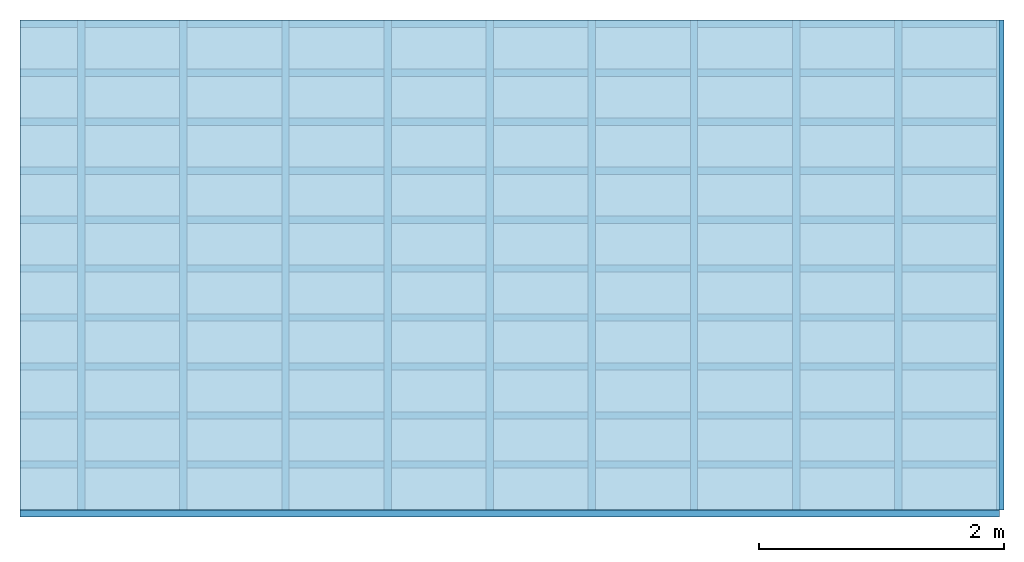
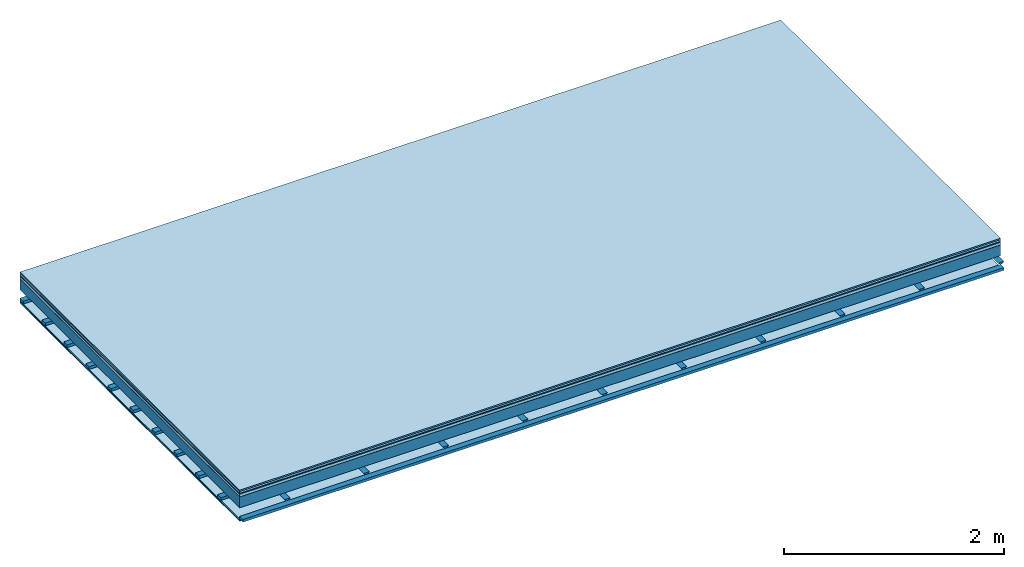
# One storey: 8 plates, 3 members, 1 element without a shape of its own.
"""IFC4 building model written with IfcOpenShell, lengths in metres."""

from ifc_helpers import new_model, si_unit, derived_unit, direction, frame, frame_2d, origin, origin_with_axes, place, context, project, spatial, polyline, rectangle, outline, extrude, material, layer, layer_set, type_object, element, aggregate, save


model = new_model("IFC4")

# Units and contexts
plan_context = context("Plan", 3, precision=1e-05, world=origin(), true_north=direction((0.0, 1.0)))
model_context = context("Model", 3, precision=1e-05, world=origin(), true_north=direction((0.0, 1.0)))
ifc_project = project(units=[si_unit("LENGTHUNIT", "METRE"), derived_unit("SOUNDPRESSUREUNIT", [(si_unit("PRESSUREUNIT", "PASCAL", prefix="MICRO"), 0)]), si_unit("ENERGYUNIT", "JOULE", prefix="MEGA"), si_unit("MASSUNIT", "GRAM", prefix="KILO"), derived_unit("THERMALTRANSMITTANCEUNIT", [(si_unit("POWERUNIT", "WATT"), 1), (si_unit("AREAUNIT", "SQUARE_METRE"), -1), (si_unit("THERMODYNAMICTEMPERATUREUNIT", "KELVIN"), -1)]), derived_unit("AREADENSITYUNIT", [(si_unit("MASSUNIT", "GRAM", prefix="KILO"), 1), (si_unit("AREAUNIT", "SQUARE_METRE"), -1)]), derived_unit("USERDEFINED", [(si_unit("ENERGYUNIT", "JOULE", prefix="MEGA"), 1), (si_unit("AREAUNIT", "SQUARE_METRE"), -1)])], contexts=[plan_context, model_context])

# Site, building, storey
site = spatial("IfcSite", under=ifc_project)
building_placement = place(None, origin())
building = spatial("IfcBuilding", under=site, at=building_placement)
storey_placement = place(building_placement, origin())
storey = spatial("IfcBuildingStorey", under=building, at=storey_placement)

# Slab, members, plates
ifc_material_1 = material(Category="11.013")
ifc_layer_1 = layer(ifc_material_1, 0.015, Name="Flooring")
ifc_material_2 = material(Category="03.007")
ifc_layer_2 = layer(ifc_material_2, 0.02, Name="On-material")
ifc_material_3 = material(Name="Wood fiber generic product", Category="10.009")
ifc_layer_3 = layer(ifc_material_3, 0.01, Name="Impact sound insulation")
ifc_material_4 = material(Name="with broken")
ifc_layer_4 = layer(ifc_material_4, 0.03, Name="on Supporting structure")
ifc_material_5 = material(Name="protection", Category="09.007")
ifc_layer_5 = layer(ifc_material_5, 0.0005, Name="Sub-floor")
ifc_material_6 = material(Name="no composite action")
ifc_layer_6 = layer(ifc_material_6, 0.0, Name="Bond")
ifc_layer_7 = layer(None, 0.12, Name="Supporting structure")
ifc_layer_8 = layer(ifc_material_6, 0.0, Name="Bond")
ifc_layer_9 = layer(None, 0.095, Name="Coupling")
ifc_layer_10 = layer(None, 0.03, Name="Battens / profiles")
ifc_material_7 = material(Name="Plasterboard type A", Category="03.008")
ifc_layer_11 = layer(ifc_material_7, 0.0125, Name="Ceiling covering 1st layer")
ifc_layer_12 = layer(ifc_material_7, 0.0125, Name="Ceiling covering layer 2")
ifc_material_8 = material(Category="04.001")
ifc_layer_13 = layer(ifc_material_8, 0.003, Name="Surface / treatment")
ifc_layer_set = layer_set([ifc_layer_1, ifc_layer_2, ifc_layer_3, ifc_layer_4, ifc_layer_5, ifc_layer_6, ifc_layer_7, ifc_layer_8, ifc_layer_9, ifc_layer_10, ifc_layer_11, ifc_layer_12, ifc_layer_13])
slab_type = type_object("IfcSlabType", Name="A2114", PredefinedType="NOTDEFINED", material=ifc_layer_set)
slab_placement = place(None, frame((0.0, 0.0, 0.0), z_axis=(0.0, 0.0, -1.0), x_axis=(1.0, 0.0, 0.0)))
slab = element("IfcSlab", 1, at=slab_placement, inside=storey, type_object=slab_type, material=ifc_layer_set, Name="Slab #1")
ifc_material_9 = material(Name="Solid timber panel")
member_1_placement = place(slab_placement, origin())
member_1 = element("IfcMember", 2, at=member_1_placement, material=ifc_material_9, Name="Supporting structure", context=plan_context, shape_type="SweptSolid", body=[
    extrude(rectangle(XDim=1.0, YDim=0.12, at=frame_2d((0.5, 0.06), x_axis=(1.0, 0.0))), frame((0.0, 4.0, 0.0755), z_axis=(0.0, -1.0, 0.0), x_axis=(1.0, 0.0, 0.0)), (0.0, 0.0, 1.0), 4.0),
    extrude(rectangle(XDim=1.0, YDim=0.12, at=frame_2d((0.5, 0.06), x_axis=(1.0, 0.0))), frame((1.0, 4.0, 0.0755), z_axis=(0.0, -1.0, 0.0), x_axis=(1.0, 0.0, 0.0)), (0.0, 0.0, 1.0), 4.0),
    extrude(rectangle(XDim=1.0, YDim=0.12, at=frame_2d((0.5, 0.06), x_axis=(1.0, 0.0))), frame((2.0, 4.0, 0.0755), z_axis=(0.0, -1.0, 0.0), x_axis=(1.0, 0.0, 0.0)), (0.0, 0.0, 1.0), 4.0),
    extrude(rectangle(XDim=1.0, YDim=0.12, at=frame_2d((0.5, 0.06), x_axis=(1.0, 0.0))), frame((3.0, 4.0, 0.0755), z_axis=(0.0, -1.0, 0.0), x_axis=(1.0, 0.0, 0.0)), (0.0, 0.0, 1.0), 4.0),
    extrude(rectangle(XDim=1.0, YDim=0.12, at=frame_2d((0.5, 0.06), x_axis=(1.0, 0.0))), frame((4.0, 4.0, 0.0755), z_axis=(0.0, -1.0, 0.0), x_axis=(1.0, 0.0, 0.0)), (0.0, 0.0, 1.0), 4.0),
    extrude(rectangle(XDim=1.0, YDim=0.12, at=frame_2d((0.5, 0.06), x_axis=(1.0, 0.0))), frame((5.0, 4.0, 0.0755), z_axis=(0.0, -1.0, 0.0), x_axis=(1.0, 0.0, 0.0)), (0.0, 0.0, 1.0), 4.0),
    extrude(rectangle(XDim=1.0, YDim=0.12, at=frame_2d((0.5, 0.06), x_axis=(1.0, 0.0))), frame((6.0, 4.0, 0.0755), z_axis=(0.0, -1.0, 0.0), x_axis=(1.0, 0.0, 0.0)), (0.0, 0.0, 1.0), 4.0),
    extrude(rectangle(XDim=1.0, YDim=0.12, at=frame_2d((0.5, 0.06), x_axis=(1.0, 0.0))), frame((7.0, 4.0, 0.0755), z_axis=(0.0, -1.0, 0.0), x_axis=(1.0, 0.0, 0.0)), (0.0, 0.0, 1.0), 4.0),
])
ifc_material_10 = material()
member_2_placement = place(slab_placement, origin())
member_2 = element("IfcMember", 3, at=member_2_placement, material=ifc_material_10, Name="Coupling", context=plan_context, shape_type="SweptSolid", body=[
    extrude(outline(polyline([(0.0, 0.0), (0.06, 0.0), (0.04, 0.02), (0.02, 0.02), (0.0, 0.0)])), frame((0.47, 4.0, 0.2705), z_axis=(0.0, -1.0, 0.0), x_axis=(1.0, 0.0, 0.0)), (0.0, 0.0, 1.0), 4.0),
    extrude(outline(polyline([(0.0, 0.0), (0.06, 0.0), (0.04, 0.02), (0.02, 0.02), (0.0, 0.0)])), frame((1.304, 4.0, 0.2705), z_axis=(0.0, -1.0, 0.0), x_axis=(1.0, 0.0, 0.0)), (0.0, 0.0, 1.0), 4.0),
    extrude(outline(polyline([(0.0, 0.0), (0.06, 0.0), (0.04, 0.02), (0.02, 0.02), (0.0, 0.0)])), frame((2.138, 4.0, 0.2705), z_axis=(0.0, -1.0, 0.0), x_axis=(1.0, 0.0, 0.0)), (0.0, 0.0, 1.0), 4.0),
    extrude(outline(polyline([(0.0, 0.0), (0.06, 0.0), (0.04, 0.02), (0.02, 0.02), (0.0, 0.0)])), frame((2.972, 4.0, 0.2705), z_axis=(0.0, -1.0, 0.0), x_axis=(1.0, 0.0, 0.0)), (0.0, 0.0, 1.0), 4.0),
    extrude(outline(polyline([(0.0, 0.0), (0.06, 0.0), (0.04, 0.02), (0.02, 0.02), (0.0, 0.0)])), frame((3.806, 4.0, 0.2705), z_axis=(0.0, -1.0, 0.0), x_axis=(1.0, 0.0, 0.0)), (0.0, 0.0, 1.0), 4.0),
    extrude(outline(polyline([(0.0, 0.0), (0.06, 0.0), (0.04, 0.02), (0.02, 0.02), (0.0, 0.0)])), frame((4.64, 4.0, 0.2705), z_axis=(0.0, -1.0, 0.0), x_axis=(1.0, 0.0, 0.0)), (0.0, 0.0, 1.0), 4.0),
    extrude(outline(polyline([(0.0, 0.0), (0.06, 0.0), (0.04, 0.02), (0.02, 0.02), (0.0, 0.0)])), frame((5.474, 4.0, 0.2705), z_axis=(0.0, -1.0, 0.0), x_axis=(1.0, 0.0, 0.0)), (0.0, 0.0, 1.0), 4.0),
    extrude(outline(polyline([(0.0, 0.0), (0.06, 0.0), (0.04, 0.02), (0.02, 0.02), (0.0, 0.0)])), frame((6.308, 4.0, 0.2705), z_axis=(0.0, -1.0, 0.0), x_axis=(1.0, 0.0, 0.0)), (0.0, 0.0, 1.0), 4.0),
    extrude(outline(polyline([(0.0, 0.0), (0.06, 0.0), (0.04, 0.02), (0.02, 0.02), (0.0, 0.0)])), frame((7.142, 4.0, 0.2705), z_axis=(0.0, -1.0, 0.0), x_axis=(1.0, 0.0, 0.0)), (0.0, 0.0, 1.0), 4.0),
    extrude(outline(polyline([(0.0, 0.0), (0.06, 0.0), (0.04, 0.02), (0.02, 0.02), (0.0, 0.0)])), frame((7.976, 4.0, 0.2705), z_axis=(0.0, -1.0, 0.0), x_axis=(1.0, 0.0, 0.0)), (0.0, 0.0, 1.0), 4.0),
])
member_3_placement = place(slab_placement, origin())
member_3 = element("IfcMember", 4, at=member_3_placement, material=ifc_material_10, Name="Battens / profiles", context=plan_context, shape_type="SweptSolid", body=[
    extrude(rectangle(XDim=0.06, YDim=0.03, at=frame_2d((0.03, 0.015), x_axis=(1.0, 0.0))), frame((0.0, 0.0, 0.2905), z_axis=(1.0, 0.0, 0.0), x_axis=(0.0, 1.0, 0.0)), (0.0, 0.0, 1.0), 8.0),
    extrude(rectangle(XDim=0.06, YDim=0.03, at=frame_2d((0.03, 0.015), x_axis=(1.0, 0.0))), frame((0.0, 0.4, 0.2905), z_axis=(1.0, 0.0, 0.0), x_axis=(0.0, 1.0, 0.0)), (0.0, 0.0, 1.0), 8.0),
    extrude(rectangle(XDim=0.06, YDim=0.03, at=frame_2d((0.03, 0.015), x_axis=(1.0, 0.0))), frame((0.0, 0.8, 0.2905), z_axis=(1.0, 0.0, 0.0), x_axis=(0.0, 1.0, 0.0)), (0.0, 0.0, 1.0), 8.0),
    extrude(rectangle(XDim=0.06, YDim=0.03, at=frame_2d((0.03, 0.015), x_axis=(1.0, 0.0))), frame((0.0, 1.2, 0.2905), z_axis=(1.0, 0.0, 0.0), x_axis=(0.0, 1.0, 0.0)), (0.0, 0.0, 1.0), 8.0),
    extrude(rectangle(XDim=0.06, YDim=0.03, at=frame_2d((0.03, 0.015), x_axis=(1.0, 0.0))), frame((0.0, 1.6, 0.2905), z_axis=(1.0, 0.0, 0.0), x_axis=(0.0, 1.0, 0.0)), (0.0, 0.0, 1.0), 8.0),
    extrude(rectangle(XDim=0.06, YDim=0.03, at=frame_2d((0.03, 0.015), x_axis=(1.0, 0.0))), frame((0.0, 2.0, 0.2905), z_axis=(1.0, 0.0, 0.0), x_axis=(0.0, 1.0, 0.0)), (0.0, 0.0, 1.0), 8.0),
    extrude(rectangle(XDim=0.06, YDim=0.03, at=frame_2d((0.03, 0.015), x_axis=(1.0, 0.0))), frame((0.0, 2.4, 0.2905), z_axis=(1.0, 0.0, 0.0), x_axis=(0.0, 1.0, 0.0)), (0.0, 0.0, 1.0), 8.0),
    extrude(rectangle(XDim=0.06, YDim=0.03, at=frame_2d((0.03, 0.015), x_axis=(1.0, 0.0))), frame((0.0, 2.8, 0.2905), z_axis=(1.0, 0.0, 0.0), x_axis=(0.0, 1.0, 0.0)), (0.0, 0.0, 1.0), 8.0),
    extrude(rectangle(XDim=0.06, YDim=0.03, at=frame_2d((0.03, 0.015), x_axis=(1.0, 0.0))), frame((0.0, 3.2, 0.2905), z_axis=(1.0, 0.0, 0.0), x_axis=(0.0, 1.0, 0.0)), (0.0, 0.0, 1.0), 8.0),
    extrude(rectangle(XDim=0.06, YDim=0.03, at=frame_2d((0.03, 0.015), x_axis=(1.0, 0.0))), frame((0.0, 3.6, 0.2905), z_axis=(1.0, 0.0, 0.0), x_axis=(0.0, 1.0, 0.0)), (0.0, 0.0, 1.0), 8.0),
    extrude(rectangle(XDim=0.06, YDim=0.03, at=frame_2d((0.03, 0.015), x_axis=(1.0, 0.0))), frame((0.0, 4.0, 0.2905), z_axis=(1.0, 0.0, 0.0), x_axis=(0.0, 1.0, 0.0)), (0.0, 0.0, 1.0), 8.0),
])
plate_1_placement = place(slab_placement, origin())
plate_1 = element("IfcPlate", 5, at=plate_1_placement, material=ifc_material_1, Name="Flooring", context=plan_context, shape_type="SweptSolid", body=[
    extrude(rectangle(XDim=8.0, YDim=4.0, at=frame_2d((4.0, 2.0), x_axis=(1.0, 0.0))), origin_with_axes(), (0.0, 0.0, 1.0), 0.015),
])
plate_2_placement = place(slab_placement, origin())
plate_2 = element("IfcPlate", 6, at=plate_2_placement, material=ifc_material_2, Name="On-material", context=plan_context, shape_type="SweptSolid", body=[
    extrude(rectangle(XDim=8.0, YDim=4.0, at=frame_2d((4.0, 2.0), x_axis=(1.0, 0.0))), frame((0.0, 0.0, 0.015), z_axis=(0.0, 0.0, 1.0), x_axis=(1.0, 0.0, 0.0)), (0.0, 0.0, 1.0), 0.02),
])
plate_3_placement = place(slab_placement, origin())
plate_3 = element("IfcPlate", 7, at=plate_3_placement, material=ifc_material_3, Name="Impact sound insulation", context=plan_context, shape_type="SweptSolid", body=[
    extrude(rectangle(XDim=8.0, YDim=4.0, at=frame_2d((4.0, 2.0), x_axis=(1.0, 0.0))), frame((0.0, 0.0, 0.035), z_axis=(0.0, 0.0, 1.0), x_axis=(1.0, 0.0, 0.0)), (0.0, 0.0, 1.0), 0.01),
])
plate_4_placement = place(slab_placement, origin())
plate_4 = element("IfcPlate", 8, at=plate_4_placement, material=ifc_material_4, Name="on Supporting structure", context=plan_context, shape_type="SweptSolid", body=[
    extrude(rectangle(XDim=8.0, YDim=4.0, at=frame_2d((4.0, 2.0), x_axis=(1.0, 0.0))), frame((0.0, 0.0, 0.045), z_axis=(0.0, 0.0, 1.0), x_axis=(1.0, 0.0, 0.0)), (0.0, 0.0, 1.0), 0.03),
])
plate_5_placement = place(slab_placement, origin())
plate_5 = element("IfcPlate", 9, at=plate_5_placement, material=ifc_material_5, Name="Sub-floor", context=plan_context, shape_type="SweptSolid", body=[
    extrude(rectangle(XDim=8.0, YDim=4.0, at=frame_2d((4.0, 2.0), x_axis=(1.0, 0.0))), frame((0.0, 0.0, 0.075), z_axis=(0.0, 0.0, 1.0), x_axis=(1.0, 0.0, 0.0)), (0.0, 0.0, 1.0), 0.0005),
])
plate_6_placement = place(slab_placement, origin())
plate_6 = element("IfcPlate", 10, at=plate_6_placement, material=ifc_material_7, Name="Ceiling covering 1st layer", context=plan_context, shape_type="SweptSolid", body=[
    extrude(rectangle(XDim=8.0, YDim=4.0, at=frame_2d((4.0, 2.0), x_axis=(1.0, 0.0))), frame((0.0, 0.0, 0.3205), z_axis=(0.0, 0.0, 1.0), x_axis=(1.0, 0.0, 0.0)), (0.0, 0.0, 1.0), 0.0125),
])
plate_7_placement = place(slab_placement, origin())
plate_7 = element("IfcPlate", 11, at=plate_7_placement, material=ifc_material_7, Name="Ceiling covering layer 2", context=plan_context, shape_type="SweptSolid", body=[
    extrude(rectangle(XDim=8.0, YDim=4.0, at=frame_2d((4.0, 2.0), x_axis=(1.0, 0.0))), frame((0.0, 0.0, 0.333), z_axis=(0.0, 0.0, 1.0), x_axis=(1.0, 0.0, 0.0)), (0.0, 0.0, 1.0), 0.0125),
])
plate_8_placement = place(slab_placement, origin())
plate_8 = element("IfcPlate", 12, at=plate_8_placement, material=ifc_material_8, Name="Surface / treatment", context=plan_context, shape_type="SweptSolid", body=[
    extrude(rectangle(XDim=8.0, YDim=4.0, at=frame_2d((4.0, 2.0), x_axis=(1.0, 0.0))), frame((0.0, 0.0, 0.3455), z_axis=(0.0, 0.0, 1.0), x_axis=(1.0, 0.0, 0.0)), (0.0, 0.0, 1.0), 0.003),
])
aggregate(slab, [plate_1, plate_2, plate_3, plate_4, plate_5, member_1, member_2, member_3, plate_6, plate_7, plate_8])

save(model, "model.ifc")
